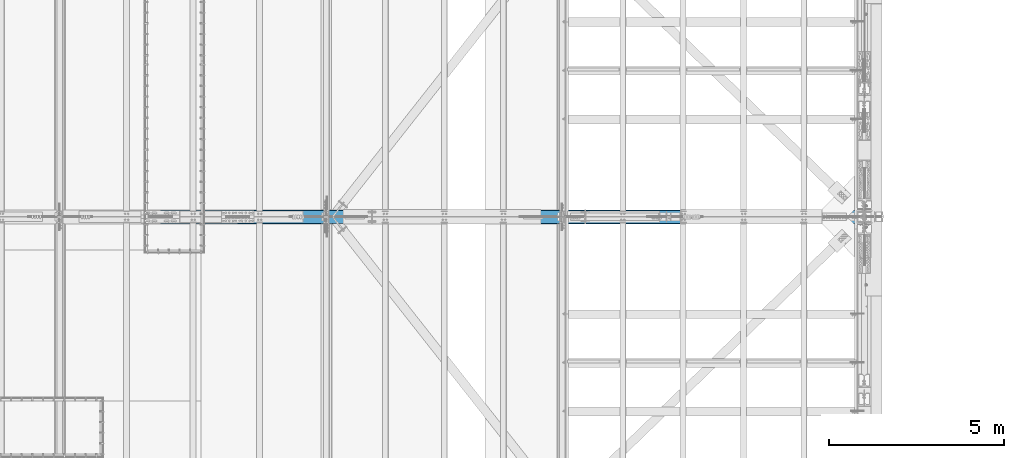
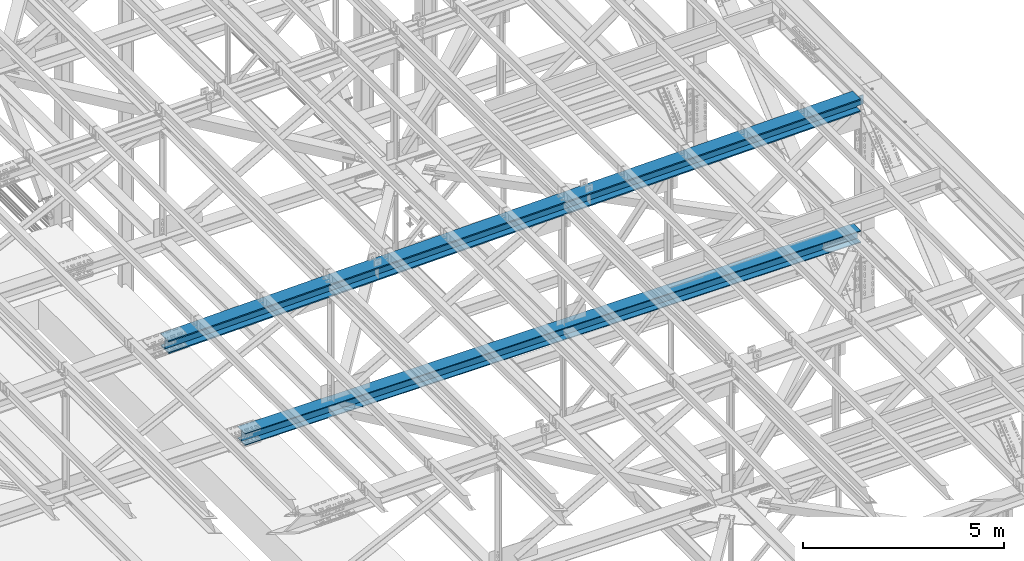
# One storey, part 1901 of 3843: 2 beams, 2 elements without a shape of their own.
"""IFC2X3 building model written with IfcOpenShell, lengths in millimetres."""

from ifc_helpers import new_model, si_unit, frame, origin_with_axes, place, context, subcontext, project, spatial, faceted_brep, material, type_object, element, aggregate, save


model = new_model("IFC2X3")

# Units and contexts
model_context = context("Model", 3, precision=1e-05, world=origin_with_axes())
body_context = subcontext(model_context, "Body", "Model", "MODEL_VIEW")
ifc_project = project(units=[si_unit("LENGTHUNIT", "METRE", prefix="MILLI"), si_unit("AREAUNIT", "SQUARE_METRE"), si_unit("VOLUMEUNIT", "CUBIC_METRE"), si_unit("MASSUNIT", "GRAM", prefix="KILO"), si_unit("TIMEUNIT", "SECOND"), si_unit("PLANEANGLEUNIT", "RADIAN"), si_unit("SOLIDANGLEUNIT", "STERADIAN"), si_unit("THERMODYNAMICTEMPERATUREUNIT", "DEGREE_CELSIUS"), si_unit("LUMINOUSINTENSITYUNIT", "LUMEN")], contexts=[model_context])

# Site, building, storey
site_placement = place(None, origin_with_axes())
site = spatial("IfcSite", under=ifc_project, at=site_placement, CompositionType="ELEMENT")
building_placement = place(site_placement, origin_with_axes())
building = spatial("IfcBuilding", under=site, at=building_placement, Name="Undefined", CompositionType="ELEMENT")
storey_placement = place(building_placement, origin_with_axes())
storey = spatial("IfcBuildingStorey", under=building, at=storey_placement, Name="Undefined", CompositionType="ELEMENT", Elevation=0.0)

# Assembly, beam
assembly_1_placement = place(storey_placement, origin_with_axes())
assembly_1 = element("IfcElementAssembly", 1, at=assembly_1_placement, inside=storey, Name="BEAM", AssemblyPlace="NOTDEFINED", PredefinedType="RIGID_FRAME")
ifc_material = material(Name="STEEL/A992")
beam_type_1 = type_object("IfcBeamType", Name="W14X193", PredefinedType="NOTDEFINED")
beam_1_placement = place(assembly_1_placement, frame((65510.881011983, 67271.9, 45930.6328143122), z_axis=(-0.019828109994094, 0.0, 0.999803403701979), x_axis=(0.999803403701979, 0.0, 0.0198281099940896)))
beam_1 = element("IfcBeam", 2, at=beam_1_placement, type_object=beam_type_1, material=ifc_material, Name="BEAM", ObjectType="W14X193", context=body_context, shape_type="Brep", body=[
    faceted_brep([(19920.4631881492, -11.1125000000029, -159.94924392306), (19920.4631881492, -200.024999999994, -159.94924392306), (19920.3932510773, -200.024999999994, -196.461676918792), (19920.3932510773, 200.024999999994, -196.461676918792), (19920.4631881492, 200.024999999994, -159.94924392306), (19920.4631881492, 11.1125000000029, -159.94924392306), (19920.4784729639, 11.1125000000029, -151.969416425891), (19920.4784729639, -11.1125000000029, -151.969416425891), (19921.4545102464, 11.1125000000029, -147.111197525126), (19921.4545102464, -11.1125000000029, -147.111197525126), (19924.2154109987, 11.1125000000029, -142.99630181562), (19924.2154109987, -11.1125000000029, -142.99630181562), (19928.3408531091, 11.1125000000029, -140.251184867528), (19928.3408531091, -11.1125000000029, -140.251184867528), (19933.2027754134, 11.1125000000029, -139.293765851617), (19933.2027754134, -11.1125000000029, -139.293765851617), (20111.3228527694, -11.1125000000029, -139.634942694793), (20111.3228527694, 11.1125000000029, -139.634942694793), (16116.5530032039, 200.024999999994, 203.035234639421), (16116.5530032039, -200.024999999994, 203.035234639421), (18131.1684570983, -200.024999999994, 200.329035620656), (18131.1684570983, 200.024999999994, 200.329035620656), (14101.9366590589, 200.024999999994, 204.968234222957), (14101.9366590589, -200.024999999994, 204.968234222957), (12087.3197214136, 200.024999999994, 206.12803408625), (12087.3197214136, -200.024999999994, 206.12803408625), (10072.702487018, 200.024999999994, 206.514634058891), (10072.702487018, -200.024999999994, 206.514634058891), (8058.08525262235, 200.024999999994, 206.128034084031), (8058.08525262235, -200.024999999994, 206.128034084031), (6043.46831497696, 200.024999999994, 204.968234218526), (6043.46831497696, -200.024999999994, 204.968234218526), (4028.85197083201, 200.024999999994, 203.035234632778), (4028.85197083201, -200.024999999994, 203.035234632778), (2014.23651693757, 200.024999999994, 200.329035611809), (2014.23651693757, -200.024999999994, 200.329035611809), (5.97224307589931, 200.024999999994, 196.860604494032), (5.97224307589931, -200.024999999994, 196.860604494032), (18131.1124038666, 11.1125000000029, 163.816578646452), (18131.1124038666, 200.024999999994, 163.816578646452), (19927.4274087431, 200.024999999994, 160.714200668932), (19927.4274087431, 11.1125000000029, 160.714200668932), (16116.5109632729, 11.1125000000029, 166.522758841376), (16116.5109632729, 200.024999999994, 166.522758841376), (14101.9086324349, 11.1125000000029, 168.455744979306), (14101.9086324349, 200.024999999994, 168.455744979306), (12087.3057081005, 11.1125000000029, 169.615536775251), (12087.3057081005, 200.024999999994, 169.615536775251), (10072.702487018, 11.1125000000029, 170.002134058763), (10072.702487018, 200.024999999994, 170.002134058763), (8058.09926593544, 11.1125000000029, 169.615536773032), (8058.09926593544, 200.024999999994, 169.615536773032), (6043.49634160107, 11.1125000000029, 168.455744974875), (6043.49634160107, 200.024999999994, 168.455744974875), (4028.89401076302, 11.1125000000029, 166.522758834741), (4028.89401076302, 200.024999999994, 166.522758834741), (2014.2925701693, 11.1125000000029, 163.816578637583), (2014.2925701693, 200.024999999994, 163.816578637583), (6.04230920456757, 11.1125000000029, 160.348171721198), (6.04230920456757, 200.024999999994, 160.348171721198), (16116.1417430096, 200.024999999994, -154.152028602359), (16116.1417430096, 11.1125000000029, -154.152028602359), (18130.6201102667, 11.1125000000029, -156.858043474946), (18130.6201102667, 200.024999999994, -156.858043474946), (14101.6624855625, 200.024999999994, -152.219160551824), (14101.6624855625, 11.1125000000029, -152.219160551824), (12087.1826346553, 200.024999999994, -151.059439608332), (12087.1826346553, 11.1125000000029, -151.059439608332), (10072.7024870181, 200.024999999994, -150.672865942302), (10072.7024870181, 11.1125000000029, -150.672865942302), (8058.22233938095, 200.024999999994, -151.059439610544), (8058.22233938095, 11.1125000000029, -151.059439610544), (6043.74248847383, 200.024999999994, -152.219160556255), (6043.74248847383, 11.1125000000029, -152.219160556255), (4029.26323102672, 200.024999999994, -154.152028608994), (4029.26323102672, 11.1125000000029, -154.152028608994), (2014.78486376959, 200.024999999994, -156.8580434838), (2014.78486376959, 11.1125000000029, -156.8580434838), (6.657672595451, 200.024999999994, -160.326237848931), (6.657672595451, 11.1125000000029, -160.326237848931), (16116.0997030786, -200.024999999994, -190.664504400411), (16116.0997030786, 200.024999999994, -190.664504400411), (18130.564057035, 200.024999999994, -193.370500449157), (18130.564057035, -200.024999999994, -193.370500449157), (14101.6344589384, -200.024999999994, -188.731649795474), (14101.6344589384, 200.024999999994, -188.731649795474), (12087.1686213423, -200.024999999994, -187.571936919339), (12087.1686213423, 200.024999999994, -187.571936919339), (10072.7024870182, -200.024999999994, -187.185365942431), (10072.7024870182, 200.024999999994, -187.185365942431), (8058.23635269406, -200.024999999994, -187.571936921551), (8058.23635269406, 200.024999999994, -187.571936921551), (6043.77051509795, -200.024999999994, -188.731649799898), (6043.77051509795, 200.024999999994, -188.731649799898), (4029.30527095776, -200.024999999994, -190.664504407046), (4029.30527095776, 200.024999999994, -190.664504407046), (2014.8409170013, -200.024999999994, -193.370500458019), (2014.8409170013, 200.024999999994, -193.370500458019), (6.72773872410471, -200.024999999994, -196.838670621779), (6.72773872410471, 200.024999999994, -196.838670621779), (16116.1417430096, -11.1125000000029, -154.152028602359), (16116.1417430096, -200.024999999994, -154.152028602359), (18130.6201102667, -200.024999999994, -156.858043474946), (18130.6201102667, -11.1125000000029, -156.858043474946), (14101.6624855625, -11.1125000000029, -152.219160551824), (14101.6624855625, -200.024999999994, -152.219160551824), (12087.1826346553, -11.1125000000029, -151.059439608332), (12087.1826346553, -200.024999999994, -151.059439608332), (10072.7024870181, -11.1125000000029, -150.672865942302), (10072.7024870181, -200.024999999994, -150.672865942302), (8058.22233938095, -11.1125000000029, -151.059439610544), (8058.22233938095, -200.024999999994, -151.059439610544), (6043.74248847383, -11.1125000000029, -152.219160556255), (6043.74248847383, -200.024999999994, -152.219160556255), (4029.26323102672, -11.1125000000029, -154.152028608994), (4029.26323102672, -200.024999999994, -154.152028608994), (2014.78486376959, -11.1125000000029, -156.8580434838), (2014.78486376959, -200.024999999994, -156.8580434838), (6.657672595451, -11.1125000000029, -160.326237848931), (6.657672595451, -200.024999999994, -160.326237848931), (6.04230920456757, -11.1125000000029, 160.348171721198), (6.04230920456757, -200.024999999994, 160.348171721198), (2014.2925701693, -11.1125000000029, 163.816578637583), (2014.2925701693, -200.024999999994, 163.816578637583), (4028.89401076302, -11.1125000000029, 166.522758834741), (4028.89401076302, -200.024999999994, 166.522758834741), (6043.49634160107, -11.1125000000029, 168.455744974875), (6043.49634160107, -200.024999999994, 168.455744974875), (8058.09926593544, -11.1125000000029, 169.615536773032), (8058.09926593544, -200.024999999994, 169.615536773032), (10072.702487018, -11.1125000000029, 170.002134058763), (10072.702487018, -200.024999999994, 170.002134058763), (12087.3057081005, -11.1125000000029, 169.615536775251), (12087.3057081005, -200.024999999994, 169.615536775251), (14101.9086324349, -11.1125000000029, 168.455744979306), (14101.9086324349, -200.024999999994, 168.455744979306), (16116.5109632729, -11.1125000000029, 166.522758841376), (16116.5109632729, -200.024999999994, 166.522758841376), (18131.1124038666, -11.1125000000029, 163.816578646452), (18131.1124038666, -200.024999999994, 163.816578646452), (19927.4274087431, -11.1125000000029, 160.714200668932), (19927.4274087431, -200.024999999994, 160.714200668932), (19927.4973458145, -200.024999999994, 197.226633664664), (19927.4973458145, 200.024999999994, 197.226633664664), (19927.4122838444, -11.1125000000029, 152.817861093485), (19927.4122838444, 11.1125000000029, 152.817861093485), (19928.3697028603, -11.1125000000029, 147.955938789179), (19928.3697028603, 11.1125000000029, 147.955938789179), (19931.1148198085, -11.1125000000029, 143.830496678798), (19931.1148198085, 11.1125000000029, 143.830496678798), (19935.2297155182, -11.1125000000029, 141.069595926419), (19935.2297155182, 11.1125000000029, 141.069595926419), (19940.087934419, -11.1125000000029, 140.093558643959), (19940.087934419, 11.1125000000029, 140.093558643959), (20116.8637157393, -11.1125000000029, 139.754956710851), (20116.8637157393, 11.1125000000029, 139.754956710851)], [[[0, 1, 2, 3, 4, 5, 6, 7]], [[7, 6, 8, 9]], [[9, 8, 10, 11]], [[11, 10, 12, 13]], [[13, 12, 14, 15]], [[16, 15, 14, 17]], [[18, 19, 20, 21]], [[22, 23, 19, 18]], [[24, 25, 23, 22]], [[26, 27, 25, 24]], [[28, 29, 27, 26]], [[30, 31, 29, 28]], [[32, 33, 31, 30]], [[34, 35, 33, 32]], [[35, 34, 36, 37]], [[38, 39, 40, 41]], [[42, 43, 39, 38]], [[44, 45, 43, 42]], [[46, 47, 45, 44]], [[48, 49, 47, 46]], [[50, 51, 49, 48]], [[52, 53, 51, 50]], [[54, 55, 53, 52]], [[56, 57, 55, 54]], [[57, 56, 58, 59]], [[60, 61, 62, 63]], [[64, 65, 61, 60]], [[66, 67, 65, 64]], [[68, 69, 67, 66]], [[70, 71, 69, 68]], [[72, 73, 71, 70]], [[74, 75, 73, 72]], [[76, 77, 75, 74]], [[77, 76, 78, 79]], [[80, 81, 82, 83]], [[84, 85, 81, 80]], [[86, 87, 85, 84]], [[88, 89, 87, 86]], [[90, 91, 89, 88]], [[92, 93, 91, 90]], [[94, 95, 93, 92]], [[96, 97, 95, 94]], [[97, 96, 98, 99]], [[100, 101, 102, 103]], [[104, 105, 101, 100]], [[106, 107, 105, 104]], [[108, 109, 107, 106]], [[110, 111, 109, 108]], [[112, 113, 111, 110]], [[114, 115, 113, 112]], [[116, 117, 115, 114]], [[117, 116, 118, 119]], [[120, 121, 37, 36, 59, 58, 79, 78, 99, 98, 119, 118]], [[122, 123, 121, 120]], [[123, 122, 124, 125]], [[125, 124, 126, 127]], [[127, 126, 128, 129]], [[129, 128, 130, 131]], [[131, 130, 132, 133]], [[133, 132, 134, 135]], [[135, 134, 136, 137]], [[137, 136, 138, 139]], [[139, 138, 140, 141]], [[20, 19, 23, 25, 27, 29, 31, 33, 35, 37, 121, 123, 125, 127, 129, 131, 133, 135, 137, 139, 141, 142]], [[21, 20, 142, 143]], [[39, 43, 45, 47, 49, 51, 53, 55, 57, 59, 36, 34, 32, 30, 28, 26, 24, 22, 18, 21, 143, 40]], [[142, 141, 140, 144, 145, 41, 40, 143]], [[146, 147, 145, 144]], [[148, 149, 147, 146]], [[150, 151, 149, 148]], [[152, 153, 151, 150]], [[154, 155, 153, 152]], [[155, 154, 16, 17]], [[12, 10, 8, 6, 5, 62, 61, 65, 67, 69, 71, 73, 75, 77, 79, 58, 56, 54, 52, 50, 48, 46, 44, 42, 38, 41, 145, 147, 149, 151, 153, 155, 17, 14]], [[63, 62, 5, 4]], [[82, 81, 85, 87, 89, 91, 93, 95, 97, 99, 78, 76, 74, 72, 70, 68, 66, 64, 60, 63, 4, 3]], [[83, 82, 3, 2]], [[102, 101, 105, 107, 109, 111, 113, 115, 117, 119, 98, 96, 94, 92, 90, 88, 86, 84, 80, 83, 2, 1]], [[103, 102, 1, 0]], [[154, 152, 150, 148, 146, 144, 140, 138, 136, 134, 132, 130, 128, 126, 124, 122, 120, 118, 116, 114, 112, 110, 108, 106, 104, 100, 103, 0, 7, 9, 11, 13, 15, 16]]]),
])
aggregate(assembly_1, [beam_1])

assembly_2_placement = place(storey_placement, origin_with_axes())
assembly_2 = element("IfcElementAssembly", 3, at=assembly_2_placement, inside=storey, Name="BEAM", AssemblyPlace="NOTDEFINED", PredefinedType="RIGID_FRAME")
beam_type_2 = type_object("IfcBeamType", Name="W14X120", PredefinedType="NOTDEFINED")
beam_2_placement = place(assembly_2_placement, frame((67716.400086141, 67271.8999969886, 42344.4103224203), z_axis=(0.00153315899956214, 0.0, 0.99999882471105), x_axis=(0.99999882471105, 0.0, -0.00153315899955695)))
beam_2 = element("IfcBeam", 4, at=beam_2_placement, type_object=beam_type_2, material=ifc_material, Name="BEAM", ObjectType="W14X120", context=body_context, shape_type="Brep", body=[
    faceted_brep([(3586.31812479814, -185.737500000003, 165.240492947494), (3586.31812479814, -7.14375000000291, 165.240492947494), (5379.61523270723, -7.14375000000291, 166.772751719756), (5379.61523270723, -185.737500000003, 166.772751719756), (1793.02164531352, -185.737500000003, 163.095330921038), (1793.02164531352, -7.14375000000291, 163.095330921038), (6.07599532067252, -185.737500000003, 160.347032091391), (6.07599532067252, -7.14375000000291, 160.347032091391), (14346.127282518, 185.737500000003, 189.052980462468), (14346.127282518, -185.737500000003, 189.052980462468), (16139.4319005039, -185.737500000003, 186.907808711221), (16139.4319005039, 185.737500000003, 186.907808711221), (12552.8220361049, 185.737500000003, 190.585246177965), (12552.8220361049, -185.737500000003, 190.585246177965), (10759.5163707401, 185.737500000003, 191.50460567612), (10759.5163707401, -185.737500000003, 191.50460567612), (8966.21049589955, 185.737500000003, 191.811058850741), (8966.21049589955, -185.737500000003, 191.811058850741), (7172.904621059, 185.737500000003, 191.504605665519), (7172.904621059, -185.737500000003, 191.504605665519), (5379.59895569428, 185.737500000003, 190.58524615677), (5379.59895569428, -185.737500000003, 190.58524615677), (3586.29370928112, 185.737500000003, 189.052980430672), (3586.29370928112, -185.737500000003, 189.052980430672), (1792.98909129531, 185.737500000003, 186.907808668839), (1792.98909129531, -185.737500000003, 186.907808668839), (6.03530269260227, 185.737500000003, 184.159497322114), (6.03530269260227, -185.737500000003, 184.159497322114), (14346.1028670012, 7.14375000000291, 165.24049297929), (14346.1028670012, 185.737500000003, 165.24049297929), (16139.3993464858, 185.737500000003, 163.095330963421), (16139.3993464858, 7.14375000000291, 163.095330963421), (12552.8057590921, 7.14375000000291, 166.772751740951), (12552.8057590921, 185.737500000003, 166.772751740951), (10759.5082322333, 7.14375000000291, 167.692107066803), (10759.5082322333, 185.737500000003, 167.692107066803), (8966.21049589964, 7.14375000000291, 167.998558850661), (8966.21049589964, 185.737500000003, 167.998558850661), (7172.91275956601, 7.14375000000291, 167.692107056209), (7172.91275956601, 185.737500000003, 167.692107056209), (5379.61523270723, 7.14375000000291, 166.772751719756), (5379.61523270723, 185.737500000003, 166.772751719756), (3586.31812479814, 7.14375000000291, 165.240492947494), (3586.31812479814, 185.737500000003, 165.240492947494), (1793.02164531352, 7.14375000000291, 163.095330921038), (1793.02164531352, 185.737500000003, 163.095330921038), (6.07599532067252, 7.14375000000291, 160.347032091391), (6.07599532067252, 185.737500000003, 160.347032091391), (14345.7740713739, 185.737500000003, -155.434338460844), (14345.7740713739, 7.14375000000291, -155.434338460844), (16138.9609523756, 7.14375000000291, -157.579369373736), (16138.9609523756, 185.737500000003, -157.579369373736), (12552.5865619862, 185.737500000003, -153.90217334417), (12552.5865619862, 7.14375000000291, -153.90217334417), (10759.3986336744, 185.737500000003, -152.982874205329), (10759.3986336744, 7.14375000000291, -152.982874205329), (8966.21049590058, 185.737500000003, -152.67644115047), (8966.21049590058, 7.14375000000291, -152.67644115047), (7173.02235812675, 185.737500000003, -152.982874215922), (7173.02235812675, 7.14375000000291, -152.982874215922), (5379.83442981496, 185.737500000003, -153.902173365364), (5379.83442981496, 7.14375000000291, -153.902173365364), (3586.64692042724, 185.737500000003, -155.43433849264), (3586.64692042724, 7.14375000000291, -155.43433849264), (1793.4600394256, 185.737500000003, -157.579369416126), (1793.4600394256, 7.14375000000291, -157.579369416126), (6.6239893786551, 185.737500000003, -160.327499682498), (6.6239893786551, 7.14375000000291, -160.327499682498), (14345.7496558571, -185.737500000003, -179.246825944021), (14345.7496558571, 185.737500000003, -179.246825944021), (16138.9283983575, 185.737500000003, -181.391847121551), (16138.9283983575, -185.737500000003, -181.391847121551), (12552.5702849734, -185.737500000003, -177.714667781183), (12552.5702849734, 185.737500000003, -177.714667781183), (10759.3904951676, -185.737500000003, -176.795372814646), (10759.3904951676, 185.737500000003, -176.795372814646), (8966.21049590064, -185.737500000003, -176.48894115055), (8966.21049590064, 185.737500000003, -176.48894115055), (7173.03049663373, -185.737500000003, -176.795372825247), (7173.03049663373, 185.737500000003, -176.795372825247), (5379.8507068279, -185.737500000003, -177.714667802378), (5379.8507068279, 185.737500000003, -177.714667802378), (3586.67133594424, -185.737500000003, -179.24682597581), (3586.67133594424, 185.737500000003, -179.24682597581), (1793.49259344382, -185.737500000003, -181.391847163934), (1793.49259344382, 185.737500000003, -181.391847163934), (6.66468200672534, -185.737500000003, -184.139964913236), (6.66468200672534, 185.737500000003, -184.139964913236), (6.6239893786551, -185.737500000003, -160.327499682498), (6.6239893786551, -7.14375000000291, -160.327499682498), (1793.4600394256, -185.737500000003, -157.579369416126), (1793.4600394256, -7.14375000000291, -157.579369416126), (3586.64692042724, -185.737500000003, -155.43433849264), (3586.64692042724, -7.14375000000291, -155.43433849264), (5379.83442981496, -185.737500000003, -153.902173365364), (5379.83442981496, -7.14375000000291, -153.902173365364), (7173.02235812675, -185.737500000003, -152.982874215922), (7173.02235812675, -7.14375000000291, -152.982874215922), (8966.21049590058, -185.737500000003, -152.67644115047), (8966.21049590058, -7.14375000000291, -152.67644115047), (10759.3986336744, -185.737500000003, -152.982874205329), (10759.3986336744, -7.14375000000291, -152.982874205329), (12552.5865619862, -185.737500000003, -153.90217334417), (12552.5865619862, -7.14375000000291, -153.90217334417), (14345.7740713739, -185.737500000003, -155.434338460844), (14345.7740713739, -7.14375000000291, -155.434338460844), (16138.9609523756, -185.737500000003, -157.579369373736), (16138.9609523756, -7.14375000000291, -157.579369373736), (17732.6411070522, -7.14375000000291, -160.03042841245), (17732.6411070522, -185.737500000003, -160.03042841245), (17732.6411070522, -147.637412141441, -160.03042841245), (16139.3993464858, -7.14375000000291, 163.095330963421), (14346.1028670012, -7.14375000000291, 165.24049297929), (12552.8057590921, -7.14375000000291, 166.772751740951), (10759.5082322333, -7.14375000000291, 167.692107066803), (8966.21049589964, -7.14375000000291, 167.998558850661), (7172.91275956601, -7.14375000000291, 167.692107056209), (17732.1494589786, -7.14375000000291, 160.645702317306), (7172.91275956601, -185.737500000003, 167.692107056209), (8966.21049589964, -185.737500000003, 167.998558850661), (10759.5082322333, -185.737500000003, 167.692107066803), (12552.8057590921, -185.737500000003, 166.772751740951), (14346.1028670012, -185.737500000003, 165.24049297929), (16139.3993464858, -185.737500000003, 163.095330963421), (17732.1494589786, -185.737500000003, 160.645702317306), (17732.1129504583, -185.737500000003, 184.458286282388), (17732.1129504583, 147.637587852645, 184.458286282388), (17732.1129504583, 185.737500000003, 184.458286282388), (17732.1129504583, -147.637412141441, 184.458286282388), (17732.1494589786, 185.737500000003, 160.645702317306), (17732.1494589786, 7.14375000000291, 160.645702317306), (17732.1494589786, 147.637587852645, 160.645702317306), (17732.5812368508, 7.14375000000291, -120.980250916968), (17732.6411070522, 7.14375000000291, -160.03042841245), (17732.2090165089, 7.14375000000291, 121.799463748081), (17732.6411070522, 185.737500000003, -160.03042841245), (17732.6411070522, 147.637587852645, -160.03042841245), (17732.6776155726, 185.737500000003, -183.84301237754), (17732.6776155726, -147.637412141441, -183.84301237754), (17732.6776155726, -185.737500000003, -183.84301237754), (17732.6776155726, 147.637587852645, -183.84301237754), (17732.1494589786, -147.637412141441, 160.645702317306)], [[[0, 1, 2, 3]], [[4, 5, 1, 0]], [[5, 4, 6, 7]], [[8, 9, 10, 11]], [[12, 13, 9, 8]], [[14, 15, 13, 12]], [[16, 17, 15, 14]], [[18, 19, 17, 16]], [[20, 21, 19, 18]], [[22, 23, 21, 20]], [[24, 25, 23, 22]], [[25, 24, 26, 27]], [[28, 29, 30, 31]], [[32, 33, 29, 28]], [[34, 35, 33, 32]], [[36, 37, 35, 34]], [[38, 39, 37, 36]], [[40, 41, 39, 38]], [[42, 43, 41, 40]], [[44, 45, 43, 42]], [[45, 44, 46, 47]], [[48, 49, 50, 51]], [[52, 53, 49, 48]], [[54, 55, 53, 52]], [[56, 57, 55, 54]], [[58, 59, 57, 56]], [[60, 61, 59, 58]], [[62, 63, 61, 60]], [[64, 65, 63, 62]], [[65, 64, 66, 67]], [[68, 69, 70, 71]], [[72, 73, 69, 68]], [[74, 75, 73, 72]], [[76, 77, 75, 74]], [[78, 79, 77, 76]], [[80, 81, 79, 78]], [[82, 83, 81, 80]], [[84, 85, 83, 82]], [[85, 84, 86, 87]], [[7, 6, 27, 26, 47, 46, 67, 66, 87, 86, 88, 89]], [[90, 91, 89, 88]], [[91, 90, 92, 93]], [[93, 92, 94, 95]], [[95, 94, 96, 97]], [[97, 96, 98, 99]], [[99, 98, 100, 101]], [[101, 100, 102, 103]], [[103, 102, 104, 105]], [[105, 104, 106, 107]], [[108, 107, 106, 109, 110]], [[111, 112, 113, 114, 115, 116, 2, 1, 5, 7, 89, 91, 93, 95, 97, 99, 101, 103, 105, 107, 108, 117]], [[3, 2, 116, 118]], [[10, 9, 13, 15, 17, 19, 21, 23, 25, 27, 6, 4, 0, 3, 118, 119, 120, 121, 122, 123, 124, 125]], [[126, 127, 11, 10, 125, 128]], [[30, 29, 33, 35, 37, 39, 41, 43, 45, 47, 26, 24, 22, 20, 18, 16, 14, 12, 8, 11, 127, 129]], [[130, 31, 30, 129, 131]], [[132, 133, 50, 49, 53, 55, 57, 59, 61, 63, 65, 67, 46, 44, 42, 40, 38, 36, 34, 32, 28, 31, 130, 134]], [[135, 51, 50, 133, 136]], [[70, 69, 73, 75, 77, 79, 81, 83, 85, 87, 66, 64, 62, 60, 58, 56, 54, 52, 48, 51, 135, 137]], [[138, 139, 71, 70, 137, 140]], [[106, 104, 102, 100, 98, 96, 94, 92, 90, 88, 86, 84, 82, 80, 78, 76, 74, 72, 68, 71, 139, 109]], [[138, 140, 137, 135, 136, 133, 132, 134, 130, 131, 129, 127, 126, 128, 125, 124, 141, 117, 108, 110, 109, 139]], [[124, 123, 111, 117, 141]], [[122, 112, 111, 123]], [[121, 113, 112, 122]], [[120, 114, 113, 121]], [[119, 115, 114, 120]], [[118, 116, 115, 119]]]),
])
aggregate(assembly_2, [beam_2])

save(model, "model.ifc")
